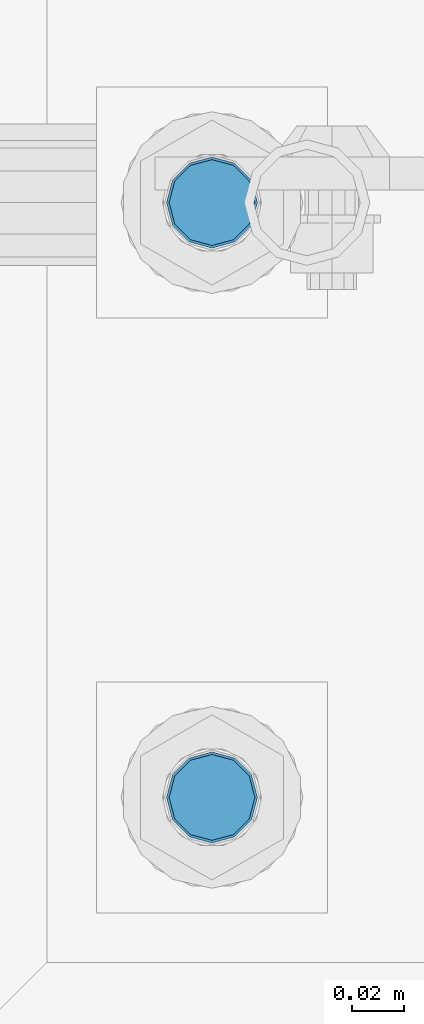
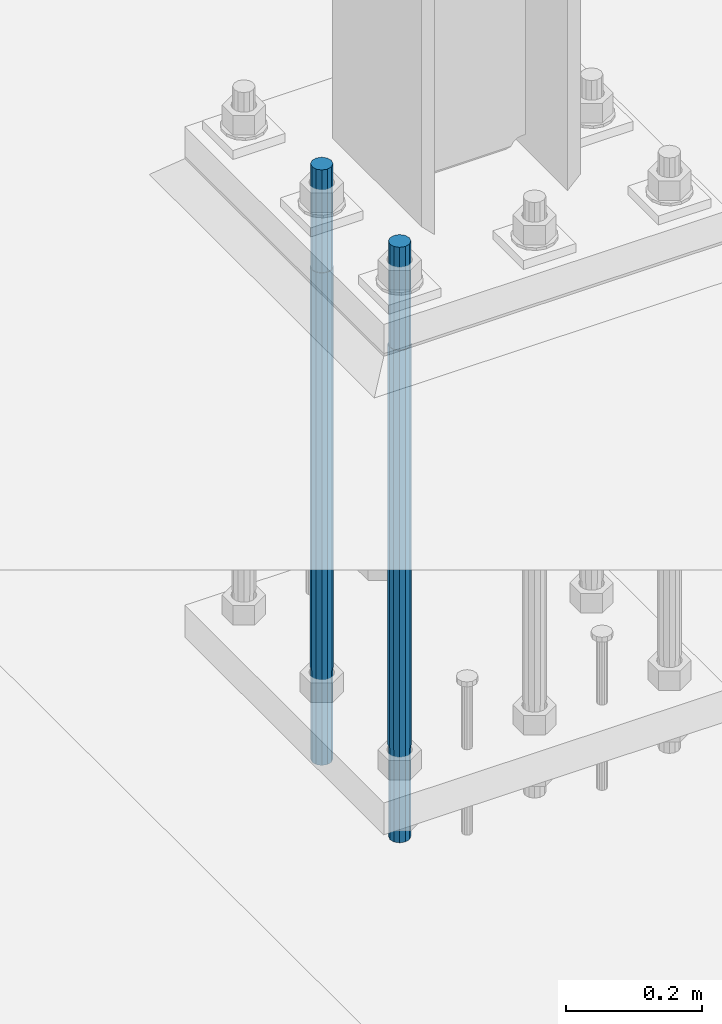
# One storey, part 562 of 1876: 2 columns, 1 element without a shape of its own.
"""IFC2X3 building model written with IfcOpenShell, lengths in millimetres."""

from ifc_helpers import new_model, si_unit, frame, origin_with_axes, place, context, subcontext, project, spatial, faceted_brep, material, type_object, element, aggregate, save


model = new_model("IFC2X3")

# Units and contexts
model_context = context("Model", 3, precision=1e-05, world=origin_with_axes())
body_context = subcontext(model_context, "Body", "Model", "MODEL_VIEW")
ifc_project = project(units=[si_unit("LENGTHUNIT", "METRE", prefix="MILLI"), si_unit("AREAUNIT", "SQUARE_METRE"), si_unit("VOLUMEUNIT", "CUBIC_METRE"), si_unit("MASSUNIT", "GRAM", prefix="KILO"), si_unit("TIMEUNIT", "SECOND"), si_unit("PLANEANGLEUNIT", "RADIAN"), si_unit("SOLIDANGLEUNIT", "STERADIAN"), si_unit("THERMODYNAMICTEMPERATUREUNIT", "DEGREE_CELSIUS"), si_unit("LUMINOUSINTENSITYUNIT", "LUMEN")], contexts=[model_context])

# Site, building, storey
site_placement = place(None, origin_with_axes())
site = spatial("IfcSite", under=ifc_project, at=site_placement, CompositionType="ELEMENT")
building_placement = place(site_placement, origin_with_axes())
building = spatial("IfcBuilding", under=site, at=building_placement, Name="Undefined", CompositionType="ELEMENT")
storey_placement = place(building_placement, origin_with_axes())
storey = spatial("IfcBuildingStorey", under=building, at=storey_placement, Name="Undefined", CompositionType="ELEMENT", Elevation=0.0)

# Assembly, columns
assembly_placement = place(storey_placement, origin_with_axes())
assembly = element("IfcElementAssembly", 1, at=assembly_placement, inside=storey, Name="TEMPLATE", AssemblyPlace="NOTDEFINED", PredefinedType="RIGID_FRAME")
ifc_material = material(Name="STEEL/F1554-GR.105")
column_type = type_object("IfcColumnType", PredefinedType="NOTDEFINED")
column_1_placement = place(assembly_placement, frame((1498.6, -7340.6, 0.0), z_axis=(1.0, 0.0, 0.0), x_axis=(0.0, 0.0, -1.0)))
column_1 = element("IfcColumn", 2, at=column_1_placement, type_object=column_type, material=ifc_material, Name="ANCHOR_BOLTS", context=body_context, shape_type="Brep", body=[
    faceted_brep([(-184.15, -14.2894191624437, 8.25), (-184.15, -8.25, 14.2894191624432), (-184.15, 0.0, 16.5), (-184.15, 8.25, 14.2894191624432), (-184.15, 14.2894191624437, 8.25), (-184.15, 16.5, 0.0), (-184.15, 14.2894191624437, -8.25), (-184.15, 8.25, -14.2894191624432), (-184.15, 0.0, -16.5), (-184.15, -8.25, -14.2894191624432), (-184.15, -14.2894191624437, -8.25), (-184.15, -16.5, 0.0), (0.0, 16.5, 0.0), (0.0, 14.2894191624437, -8.25), (0.0, 8.25, -14.2894191624432), (0.0, 0.0, -16.5), (0.0, -8.25, -14.2894191624432), (0.0, -14.2894191624437, -8.25), (0.0, -16.5, 0.0), (0.0, -14.2894191624437, 8.25), (0.0, -8.25, 14.2894191624432), (0.0, 0.0, 16.5), (0.0, 8.25, 14.2894191624432), (0.0, 14.2894191624437, 8.25), (0.0, -15.1229686135858, 8.73125000000073), (0.0, -8.73124999999999, 15.1229686135848), (0.0, 0.0, 17.4625000000015), (0.0, 8.73124999999999, 15.1229686135848), (0.0, 15.1229686135858, 8.73125000000073), (0.0, 17.4625, 0.0), (0.0, 15.1229686135858, -8.73125000000073), (0.0, 8.73124999999999, -15.1229686135848), (0.0, 0.0, -17.4625000000015), (0.0, -8.73124999999999, -15.1229686135848), (0.0, -15.1229686135857, -8.73125000000073), (0.0, -17.4625, 0.0), (717.55, -17.4624999999996, 0.0), (717.55, -15.1229686135857, 8.73125000000005), (717.55, -8.73124999999982, 15.1229686135857), (717.55, 0.0, 17.4625000000001), (717.55, 8.73124999999982, 15.1229686135857), (717.55, 15.1229686135857, 8.73125000000005), (717.55, 17.4624999999996, 0.0), (717.55, 15.1229686135857, -8.73125000000005), (717.55, 8.73124999999982, -15.1229686135857), (717.55, 0.0, -17.4625000000001), (717.55, -8.73124999999982, -15.1229686135857), (717.55, -15.1229686135857, -8.73125000000005), (717.55, -8.25, 14.2894191624432), (717.55, 0.0, 16.5), (717.55, 8.25, 14.2894191624432), (717.55, 14.2894191624437, 8.25), (717.55, 16.5, 0.0), (717.55, 14.2894191624437, -8.25), (717.55, 8.25, -14.2894191624432), (717.55, 0.0, -16.5), (717.55, -8.25, -14.2894191624432), (717.55, -14.2894191624437, -8.25), (717.55, -16.5, 0.0), (717.55, -14.2894191624437, 8.25), (882.65, -8.25, -14.2894191624432), (882.65, 0.0, -16.5), (882.65, 8.25, -14.2894191624432), (882.65, 14.2894191624437, -8.25), (882.65, 16.5, 0.0), (882.65, 14.2894191624437, 8.25), (882.65, 8.25, 14.2894191624432), (882.65, 0.0, 16.5), (882.65, -8.25, 14.2894191624432), (882.65, -14.2894191624437, 8.25), (882.65, -16.5, 0.0), (882.65, -14.2894191624437, -8.25)], [[[0, 1, 2, 3, 4, 5, 6, 7, 8, 9, 10, 11]], [[6, 5, 12, 13]], [[7, 6, 13, 14]], [[8, 7, 14, 15]], [[9, 8, 15, 16]], [[10, 9, 16, 17]], [[11, 10, 17, 18]], [[0, 11, 18, 19]], [[1, 0, 19, 20]], [[2, 1, 20, 21]], [[3, 2, 21, 22]], [[4, 3, 22, 23]], [[5, 4, 23, 12]], [[24, 25, 26, 27, 28, 29, 30, 31, 32, 33, 34, 35], [22, 21, 20, 19, 18, 17, 16, 15, 14, 13, 12, 23]], [[24, 35, 36, 37]], [[25, 24, 37, 38]], [[26, 25, 38, 39]], [[27, 26, 39, 40]], [[28, 27, 40, 41]], [[29, 28, 41, 42]], [[30, 29, 42, 43]], [[31, 30, 43, 44]], [[32, 31, 44, 45]], [[33, 32, 45, 46]], [[34, 33, 46, 47]], [[35, 34, 47, 36]], [[46, 45, 44, 43, 42, 41, 40, 39, 38, 37, 36, 47], [48, 49, 50, 51, 52, 53, 54, 55, 56, 57, 58, 59]], [[60, 61, 62, 63, 64, 65, 66, 67, 68, 69, 70, 71]], [[68, 67, 49, 48]], [[69, 68, 48, 59]], [[70, 69, 59, 58]], [[71, 70, 58, 57]], [[60, 71, 57, 56]], [[61, 60, 56, 55]], [[62, 61, 55, 54]], [[63, 62, 54, 53]], [[64, 63, 53, 52]], [[65, 64, 52, 51]], [[66, 65, 51, 50]], [[67, 66, 50, 49]]]),
])
column_2_placement = place(assembly_placement, frame((1498.6, -7112.0, 0.0), z_axis=(1.0, 0.0, 0.0), x_axis=(0.0, 0.0, -1.0)))
column_2 = element("IfcColumn", 3, at=column_2_placement, type_object=column_type, material=ifc_material, Name="ANCHOR_BOLTS", context=body_context, shape_type="Brep", body=[
    faceted_brep([(-184.15, -14.2894191624437, 8.25), (-184.15, -8.25, 14.2894191624432), (-184.15, 0.0, 16.5), (-184.15, 8.25, 14.2894191624432), (-184.15, 14.2894191624437, 8.25), (-184.15, 16.5, 0.0), (-184.15, 14.2894191624437, -8.25), (-184.15, 8.25, -14.2894191624432), (-184.15, 0.0, -16.5), (-184.15, -8.25, -14.2894191624432), (-184.15, -14.2894191624437, -8.25), (-184.15, -16.5, 0.0), (0.0, 16.5, 0.0), (0.0, 14.2894191624437, -8.25), (0.0, 8.25, -14.2894191624432), (0.0, 0.0, -16.5), (0.0, -8.25, -14.2894191624432), (0.0, -14.2894191624437, -8.25), (0.0, -16.5, 0.0), (0.0, -14.2894191624437, 8.25), (0.0, -8.25, 14.2894191624432), (0.0, 0.0, 16.5), (0.0, 8.25, 14.2894191624432), (0.0, 14.2894191624437, 8.25), (0.0, -15.1229686135858, 8.73125000000073), (0.0, -8.73124999999999, 15.1229686135848), (0.0, 0.0, 17.4625000000015), (0.0, 8.73124999999999, 15.1229686135848), (0.0, 15.1229686135858, 8.73125000000073), (0.0, 17.4625, 0.0), (0.0, 15.1229686135858, -8.73125000000073), (0.0, 8.73124999999999, -15.1229686135848), (0.0, 0.0, -17.4625000000015), (0.0, -8.73124999999999, -15.1229686135848), (0.0, -15.1229686135857, -8.73125000000073), (0.0, -17.4625, 0.0), (717.55, -17.4624999999996, 0.0), (717.55, -15.1229686135857, 8.73125000000005), (717.55, -8.73124999999982, 15.1229686135857), (717.55, 0.0, 17.4625000000001), (717.55, 8.73124999999982, 15.1229686135857), (717.55, 15.1229686135857, 8.73125000000005), (717.55, 17.4624999999996, 0.0), (717.55, 15.1229686135857, -8.73125000000005), (717.55, 8.73124999999982, -15.1229686135857), (717.55, 0.0, -17.4625000000001), (717.55, -8.73124999999982, -15.1229686135857), (717.55, -15.1229686135857, -8.73125000000005), (717.55, -8.25, 14.2894191624432), (717.55, 0.0, 16.5), (717.55, 8.25, 14.2894191624432), (717.55, 14.2894191624437, 8.25), (717.55, 16.5, 0.0), (717.55, 14.2894191624437, -8.25), (717.55, 8.25, -14.2894191624432), (717.55, 0.0, -16.5), (717.55, -8.25, -14.2894191624432), (717.55, -14.2894191624437, -8.25), (717.55, -16.5, 0.0), (717.55, -14.2894191624437, 8.25), (882.65, -8.25, -14.2894191624432), (882.65, 0.0, -16.5), (882.65, 8.25, -14.2894191624432), (882.65, 14.2894191624437, -8.25), (882.65, 16.5, 0.0), (882.65, 14.2894191624437, 8.25), (882.65, 8.25, 14.2894191624432), (882.65, 0.0, 16.5), (882.65, -8.25, 14.2894191624432), (882.65, -14.2894191624437, 8.25), (882.65, -16.5, 0.0), (882.65, -14.2894191624437, -8.25)], [[[0, 1, 2, 3, 4, 5, 6, 7, 8, 9, 10, 11]], [[6, 5, 12, 13]], [[7, 6, 13, 14]], [[8, 7, 14, 15]], [[9, 8, 15, 16]], [[10, 9, 16, 17]], [[11, 10, 17, 18]], [[0, 11, 18, 19]], [[1, 0, 19, 20]], [[2, 1, 20, 21]], [[3, 2, 21, 22]], [[4, 3, 22, 23]], [[5, 4, 23, 12]], [[24, 25, 26, 27, 28, 29, 30, 31, 32, 33, 34, 35], [22, 21, 20, 19, 18, 17, 16, 15, 14, 13, 12, 23]], [[24, 35, 36, 37]], [[25, 24, 37, 38]], [[26, 25, 38, 39]], [[27, 26, 39, 40]], [[28, 27, 40, 41]], [[29, 28, 41, 42]], [[30, 29, 42, 43]], [[31, 30, 43, 44]], [[32, 31, 44, 45]], [[33, 32, 45, 46]], [[34, 33, 46, 47]], [[35, 34, 47, 36]], [[46, 45, 44, 43, 42, 41, 40, 39, 38, 37, 36, 47], [48, 49, 50, 51, 52, 53, 54, 55, 56, 57, 58, 59]], [[60, 61, 62, 63, 64, 65, 66, 67, 68, 69, 70, 71]], [[68, 67, 49, 48]], [[69, 68, 48, 59]], [[70, 69, 59, 58]], [[71, 70, 58, 57]], [[60, 71, 57, 56]], [[61, 60, 56, 55]], [[62, 61, 55, 54]], [[63, 62, 54, 53]], [[64, 63, 53, 52]], [[65, 64, 52, 51]], [[66, 65, 51, 50]], [[67, 66, 50, 49]]]),
])
aggregate(assembly, [column_1, column_2])

save(model, "model.ifc")
